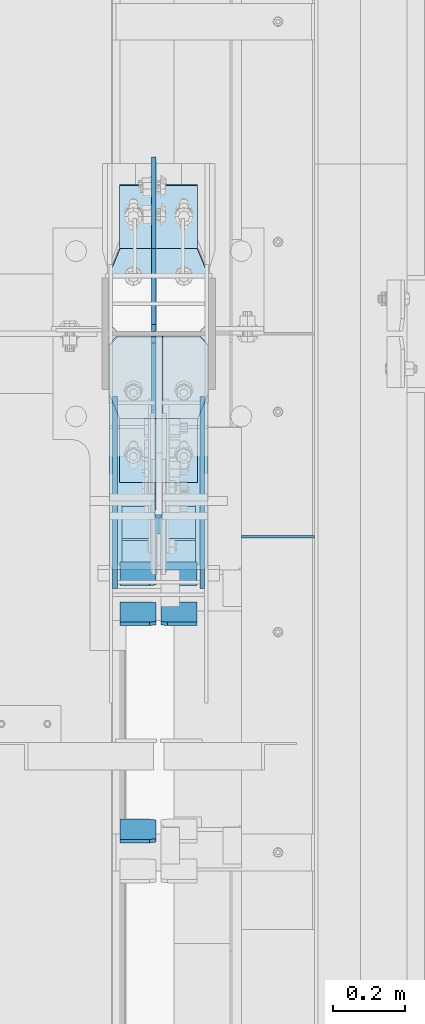
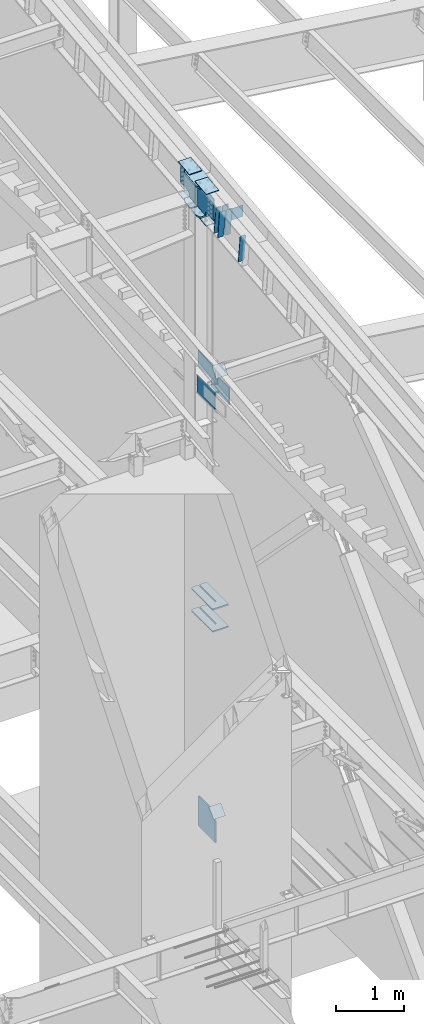
# One storey, part 1034 of 1179: 23 plates, 5 elements without a shape of their own.
"""IFC2X3 building model written with IfcOpenShell, lengths in millimetres."""

from ifc_helpers import new_model, si_unit, frame, origin_with_axes, place, context, subcontext, project, spatial, faceted_brep, material, type_object, element, aggregate, save


model = new_model("IFC2X3")

# Units and contexts
model_context = context("Model", 3, precision=1e-05, world=origin_with_axes())
body_context = subcontext(model_context, "Body", "Model", "MODEL_VIEW")
ifc_project = project(units=[si_unit("LENGTHUNIT", "METRE", prefix="MILLI"), si_unit("AREAUNIT", "SQUARE_METRE"), si_unit("VOLUMEUNIT", "CUBIC_METRE"), si_unit("MASSUNIT", "GRAM", prefix="KILO"), si_unit("TIMEUNIT", "SECOND"), si_unit("PLANEANGLEUNIT", "RADIAN"), si_unit("SOLIDANGLEUNIT", "STERADIAN"), si_unit("THERMODYNAMICTEMPERATUREUNIT", "DEGREE_CELSIUS"), si_unit("LUMINOUSINTENSITYUNIT", "LUMEN")], contexts=[model_context])

# Site, building, storey
site_placement = place(None, origin_with_axes())
site = spatial("IfcSite", under=ifc_project, at=site_placement, CompositionType="ELEMENT")
building_placement = place(site_placement, origin_with_axes())
building = spatial("IfcBuilding", under=site, at=building_placement, Name="Undefined", CompositionType="ELEMENT")
storey_placement = place(building_placement, origin_with_axes())
storey = spatial("IfcBuildingStorey", under=building, at=storey_placement, Name="Undefined", CompositionType="ELEMENT", Elevation=0.0)

# Assembly, plates
assembly_1_placement = place(storey_placement, origin_with_axes())
assembly_1 = element("IfcElementAssembly", 1, at=assembly_1_placement, inside=storey, Name="COLUMN", AssemblyPlace="NOTDEFINED", PredefinedType="RIGID_FRAME")
ifc_material_1 = material(Name="STEEL/A572-GR.50")
plate_type_1 = type_object("IfcPlateType", PredefinedType="NOTDEFINED")
plate_1_placement = place(assembly_1_placement, frame((24171.275012207, 18575.0015696771, 3694.1125), z_axis=(0.0, 1.0, 0.0), x_axis=(1.0, 0.0, 0.0)))
plate_1 = element("IfcPlate", 2, at=plate_1_placement, type_object=plate_type_1, material=ifc_material_1, Name="PLATE", context=body_context, shape_type="Brep", body=[
    faceted_brep([(125.412487792968, -11.1125000000002, 646.448430322878), (125.412487792968, -11.1125000000002, 153.987500190735), (125.412487792968, 11.1125000000002, 153.987500190735), (125.412487792968, 11.1125000000002, 646.448430322878), (126.258376502454, -11.1125000000002, 149.734930475586), (126.258376502454, 11.1125000000002, 149.734930475586), (128.667263742896, -11.1125000000002, 146.12977594993), (128.667263742896, 11.1125000000002, 146.12977594993), (132.272418268556, -11.1125000000002, 143.720888709488), (132.272418268556, 11.1125000000002, 143.720888709488), (136.524987602239, -11.1125000000002, 142.875), (136.524987602239, 11.1125000000002, 142.875), (140.777557317386, -11.1125000000002, 143.720888709488), (140.777557317386, 11.1125000000002, 143.720888709488), (144.382711843045, -11.1125000000002, 146.12977594993), (144.382711843045, 11.1125000000002, 146.12977594993), (146.791599083488, -11.1125000000002, 149.734930475586), (146.791599083488, 11.1125000000002, 149.734930475586), (147.637487792974, -11.1125000000002, 153.987500190735), (147.637487792974, 11.1125000000002, 153.987500190735), (147.637487792974, -11.1125000000002, 646.448430322878), (147.637487792974, 11.1125000000002, 646.448430322878), (0.0, -11.1125000000002, 624.223429941409), (22.2250003814697, -11.1125000000002, 646.448430322878), (22.2250003814697, 11.1125000000002, 646.448430322878), (0.0, 11.1125000000002, 624.223429941409), (0.0, -11.1125000000002, 15.875), (0.0, 11.1125000000002, 15.875), (6.34999990463257, -11.1125000000002, 0.0), (6.34999990463257, 11.1125000000002, 0.0), (266.699987888336, -11.1125000000002, 0.0), (266.699987888336, 11.1125000000002, 0.0), (273.049987792969, -11.1125000000002, 15.875), (273.049987792969, 11.1125000000002, 15.875), (273.049987792969, -11.1125000000002, 624.223429941409), (273.049987792969, 11.1125000000002, 624.223429941409), (250.824987411499, -11.1125000000002, 646.448430322878), (250.824987411499, 11.1125000000002, 646.448430322878)], [[[0, 1, 2, 3]], [[4, 5, 2, 1]], [[6, 7, 5, 4]], [[8, 9, 7, 6]], [[10, 11, 9, 8]], [[12, 13, 11, 10]], [[14, 15, 13, 12]], [[16, 17, 15, 14]], [[18, 19, 17, 16]], [[20, 21, 19, 18]], [[22, 23, 24, 25]], [[26, 22, 25, 27]], [[28, 26, 27, 29]], [[30, 28, 29, 31]], [[32, 30, 31, 33]], [[34, 32, 33, 35]], [[36, 34, 35, 37]], [[16, 14, 12, 10, 8, 6, 4, 1, 0, 23, 22, 26, 28, 30, 32, 34, 36, 20, 18]], [[24, 23, 0, 3]], [[37, 35, 33, 31, 29, 27, 25, 24, 3, 2, 5, 7, 9, 11, 13, 15, 17, 19, 21]], [[36, 37, 21, 20]]]),
])
plate_2_placement = place(assembly_1_placement, frame((24171.275012207, 18575.0015696771, 4090.9875), z_axis=(0.0, 1.0, 0.0), x_axis=(1.0, 0.0, 0.0)))
plate_2 = element("IfcPlate", 3, at=plate_2_placement, type_object=plate_type_1, material=ifc_material_1, Name="PLATE", context=body_context, shape_type="Brep", body=[
    faceted_brep([(125.412487792968, -11.1125000000002, 646.448430322878), (125.412487792968, -11.1125000000002, 153.987500190735), (125.412487792968, 11.1125000000002, 153.987500190735), (125.412487792968, 11.1125000000002, 646.448430322878), (126.258376502454, -11.1125000000002, 149.734930475586), (126.258376502454, 11.1125000000002, 149.734930475586), (128.667263742896, -11.1125000000002, 146.12977594993), (128.667263742896, 11.1125000000002, 146.12977594993), (132.272418268556, -11.1125000000002, 143.720888709488), (132.272418268556, 11.1125000000002, 143.720888709488), (136.524987602239, -11.1125000000002, 142.875), (136.524987602239, 11.1125000000002, 142.875), (140.777557317386, -11.1125000000002, 143.720888709488), (140.777557317386, 11.1125000000002, 143.720888709488), (144.382711843045, -11.1125000000002, 146.12977594993), (144.382711843045, 11.1125000000002, 146.12977594993), (146.791599083488, -11.1125000000002, 149.734930475586), (146.791599083488, 11.1125000000002, 149.734930475586), (147.637487792974, -11.1125000000002, 153.987500190735), (147.637487792974, 11.1125000000002, 153.987500190735), (147.637487792974, -11.1125000000002, 646.448430322878), (147.637487792974, 11.1125000000002, 646.448430322878), (0.0, -11.1125000000002, 624.223429941409), (22.2250003814697, -11.1125000000002, 646.448430322878), (22.2250003814697, 11.1125000000002, 646.448430322878), (0.0, 11.1125000000002, 624.223429941409), (0.0, -11.1125000000002, 15.875), (0.0, 11.1125000000002, 15.875), (6.34999990463257, -11.1125000000002, 0.0), (6.34999990463257, 11.1125000000002, 0.0), (266.699987888336, -11.1125000000002, 0.0), (266.699987888336, 11.1125000000002, 0.0), (273.049987792969, -11.1125000000002, 15.875), (273.049987792969, 11.1125000000002, 15.875), (273.049987792969, -11.1125000000002, 624.223429941409), (273.049987792969, 11.1125000000002, 624.223429941409), (250.824987411499, -11.1125000000002, 646.448430322878), (250.824987411499, 11.1125000000002, 646.448430322878)], [[[0, 1, 2, 3]], [[4, 5, 2, 1]], [[6, 7, 5, 4]], [[8, 9, 7, 6]], [[10, 11, 9, 8]], [[12, 13, 11, 10]], [[14, 15, 13, 12]], [[16, 17, 15, 14]], [[18, 19, 17, 16]], [[20, 21, 19, 18]], [[22, 23, 24, 25]], [[26, 22, 25, 27]], [[28, 26, 27, 29]], [[30, 28, 29, 31]], [[32, 30, 31, 33]], [[34, 32, 33, 35]], [[36, 34, 35, 37]], [[16, 14, 12, 10, 8, 6, 4, 1, 0, 23, 22, 26, 28, 30, 32, 34, 36, 20, 18]], [[24, 23, 0, 3]], [[37, 35, 33, 31, 29, 27, 25, 24, 3, 2, 5, 7, 9, 11, 13, 15, 17, 19, 21]], [[36, 37, 21, 20]]]),
])

# Assembly, plate
assembly_2_placement = place(storey_placement, origin_with_axes())
assembly_2 = element("IfcElementAssembly", 4, at=assembly_2_placement, inside=storey, Name="BEAM", AssemblyPlace="NOTDEFINED", PredefinedType="RIGID_FRAME")
ifc_material_2 = material(Name="STEEL/A36")
plate_type_2 = type_object("IfcPlateType", PredefinedType="NOTDEFINED")
plate_3_placement = place(assembly_2_placement, frame((24739.6, 18665.8250005413, 11099.2055869161), z_axis=(0.0, 0.0, -1.0), x_axis=(-1.0, 0.0, 0.0)))
plate_3 = element("IfcPlate", 5, at=plate_3_placement, type_object=plate_type_2, material=ifc_material_2, Name="CAP_PLATE", context=body_context, shape_type="Brep", body=[
    faceted_brep([(0.0, -3.17500000000109, 0.0), (0.0, -3.17499999999927, 204.492999998953), (0.0, 3.17499999999927, 204.492999998953), (0.0, 3.17500000000109, 7.27595761418343e-12), (203.199999999997, -3.17499999999927, 204.492999998953), (203.199999999997, 3.17499999999927, 204.492999998953), (203.199999999997, -3.17499999999927, 3.63797880709171e-12), (203.199999999997, 3.17499999999382, -3.63797880709171e-12)], [[[0, 1, 2, 3]], [[1, 4, 5, 2]], [[4, 6, 7, 5]], [[6, 0, 3, 7]], [[5, 7, 3, 2]], [[6, 4, 1, 0]]]),
])
aggregate(assembly_2, [plate_3])

assembly_3_placement = place(storey_placement, origin_with_axes())
assembly_3 = element("IfcElementAssembly", 6, at=assembly_3_placement, inside=storey, Name="Plate", AssemblyPlace="NOTDEFINED", PredefinedType="RIGID_FRAME")
plate_4_placement = place(assembly_3_placement, frame((24206.2, 18538.107881068, 8241.67671273193), z_axis=(0.0, 0.591857899923162, 0.806042322895358), x_axis=(1.0, 0.0, 0.0)))
plate_4 = element("IfcPlate", 7, at=plate_4_placement, type_object=plate_type_2, material=ifc_material_2, Name="Plate", context=body_context, shape_type="Brep", body=[
    faceted_brep([(0.0, -3.17500000000109, 0.0), (0.0, -3.17500000000291, 203.200000000368), (0.0, 3.17499999998836, 203.200000000361), (0.0, 3.17500000000109, 7.27595761418343e-12), (203.199999999997, -3.17500000000291, 203.200000000368), (203.199999999997, 3.17499999998836, 203.200000000361), (203.199999999997, -3.17499999999927, 3.63797880709171e-12), (203.199999999997, 3.17499999999382, -3.63797880709171e-12)], [[[0, 1, 2, 3]], [[1, 4, 5, 2]], [[4, 6, 7, 5]], [[6, 0, 3, 7]], [[5, 7, 3, 2]], [[6, 4, 1, 0]]]),
])
aggregate(assembly_3, [plate_4])

assembly_4_placement = place(storey_placement, origin_with_axes())
assembly_4 = element("IfcElementAssembly", 8, at=assembly_4_placement, inside=storey, Name="Plate", AssemblyPlace="NOTDEFINED", PredefinedType="RIGID_FRAME")
plate_5_placement = place(assembly_4_placement, frame((24206.2, 18604.2796707284, 297.334563911108), z_axis=(0.0, 0.727605443744036, 0.68599585875867), x_axis=(1.0, 0.0, 0.0)))
plate_5 = element("IfcPlate", 9, at=plate_5_placement, type_object=plate_type_2, material=ifc_material_2, Name="Plate", context=body_context, shape_type="Brep", body=[
    faceted_brep([(0.0, -3.17500000000109, 0.0), (0.0, -3.17500000000291, 203.200000000368), (0.0, 3.17499999998836, 203.200000000361), (0.0, 3.17500000000109, 7.27595761418343e-12), (203.199999999997, -3.17500000000291, 203.200000000368), (203.199999999997, 3.17499999998836, 203.200000000361), (203.199999999997, -3.17499999999927, 3.63797880709171e-12), (203.199999999997, 3.17499999999382, -3.63797880709171e-12)], [[[0, 1, 2, 3]], [[1, 4, 5, 2]], [[4, 6, 7, 5]], [[6, 0, 3, 7]], [[5, 7, 3, 2]], [[6, 4, 1, 0]]]),
])
aggregate(assembly_4, [plate_5])

# Plate
plate_type_3 = type_object("IfcPlateType", PredefinedType="NOTDEFINED")
plate_6_placement = place(assembly_1_placement, frame((24171.2749999998, 18991.1139130949, 11378.5871510539), z_axis=(1.0, 0.0, 0.0), x_axis=(0.0, 0.993683229349742, 0.112221387039499)))
plate_6 = element("IfcPlate", 10, at=plate_6_placement, type_object=plate_type_3, material=ifc_material_2, Name="PLATE", context=body_context, shape_type="Brep", body=[
    faceted_brep([(404.009737741189, -14.2874999996602, 8.31619217933621e-11), (71.43750000002, -14.287499999984, 2.90469870378729e-11), (71.4375000000155, 14.2874999999949, 2.90469870378729e-11), (404.009737741166, 14.2875000003405, 8.31619217933621e-11), (477.034739267168, 14.2875000004005, 30.162500381568), (473.810043726306, -14.287499999602, 28.8305609300143), (477.034739268025, 14.2875000004024, 242.887499623284), (473.810043726306, -14.287499999602, 244.219439075195), (404.009737742264, 14.2875000003405, 273.05000000474), (404.00973774229, -14.2874999996602, 273.05000000474), (71.4375000016116, -14.2874999999858, 273.049999999798), (71.4375000016071, 14.2874999999967, 273.049999999798), (4.20644072178584, 14.2875000000058, 244.663552394444), (0.979329666730337, -14.2874999999967, 243.30099437618), (0.979329666730337, -14.2874999999967, 29.7490056281208), (4.20644072178584, 14.2875000000058, 28.3864476098539)], [[[0, 1, 2, 3]], [[0, 3, 4, 5]], [[5, 4, 6, 7]], [[8, 9, 7, 6]], [[10, 9, 8, 11]], [[10, 11, 12, 13]], [[1, 0, 5, 7, 9, 10, 13, 14]], [[2, 1, 14, 15]], [[11, 8, 6, 4, 3, 2, 15, 12]], [[14, 13, 12, 15]]]),
])

plate_type_4 = type_object("IfcPlateType", PredefinedType="NOTDEFINED")
plate_7_placement = place(assembly_1_placement, frame((24428.45, 18523.1248035139, 8013.7), z_axis=(0.0, 0.0, -1.0), x_axis=(0.0, 1.0, 0.0)))
plate_7 = element("IfcPlate", 11, at=plate_7_placement, type_object=plate_type_4, material=ifc_material_1, Name="PLATE", context=body_context, shape_type="Brep", body=[
    faceted_brep([(0.0, -6.34999999999854, 0.0), (0.0, -6.34999999999854, 304.799999999999), (0.0, 6.34999999999854, 304.799999999999), (0.0, 6.34999999999854, 0.0), (531.637696486086, -6.34999999999854, 304.799999999999), (531.637696486086, 6.34999999999854, 304.799999999999), (531.637696486086, -6.34999999999854, 0.0), (531.637696486086, 6.34999999999854, 0.0)], [[[0, 1, 2, 3]], [[1, 4, 5, 2]], [[4, 6, 7, 5]], [[6, 0, 3, 7]], [[5, 7, 3, 2]], [[6, 4, 1, 0]]]),
])

plate_8_placement = place(assembly_1_placement, frame((24187.15, 18523.1248035139, 8013.7), z_axis=(0.0, 0.0, -1.0), x_axis=(0.0, 1.0, 0.0)))
plate_8 = element("IfcPlate", 12, at=plate_8_placement, type_object=plate_type_4, material=ifc_material_1, Name="PLATE", context=body_context, shape_type="Brep", body=[
    faceted_brep([(0.0, -6.34999999999854, 0.0), (0.0, -6.34999999999854, 304.799999999999), (0.0, 6.34999999999854, 304.799999999999), (0.0, 6.34999999999854, 0.0), (531.637696486086, -6.34999999999854, 304.799999999999), (531.637696486086, 6.34999999999854, 304.799999999999), (531.637696486086, -6.34999999999854, 0.0), (531.637696486086, 6.34999999999854, 0.0)], [[[0, 1, 2, 3]], [[1, 4, 5, 2]], [[4, 6, 7, 5]], [[6, 0, 3, 7]], [[5, 7, 3, 2]], [[6, 4, 1, 0]]]),
])

plate_type_5 = type_object("IfcPlateType", PredefinedType="NOTDEFINED")
plate_9_placement = place(assembly_1_placement, frame((24199.850003078, 19638.8732407573, 11472.5223933958), z_axis=(1.0, 0.0, 0.0), x_axis=(0.0, -0.993676146336441, -0.112284087038017)))
plate_9 = element("IfcPlate", 13, at=plate_9_placement, type_object=plate_type_5, material=ifc_material_1, Name="PLATE", context=body_context, shape_type="Brep", body=[
    faceted_brep([(0.0, -6.34999999999854, 0.0), (0.0, -6.350000000004, 215.899993896484), (0.0, 6.35000000000582, 215.899993896484), (0.0, 6.34999999999854, 0.0), (330.200000001782, -6.34999999994034, 215.899993896483), (330.200000001782, 6.35000000006767, 215.899993896483), (330.200000001782, -6.34999999994034, -1.47792889038101e-12), (330.200000001782, 6.35000000006767, -1.47792889038101e-12)], [[[0, 1, 2, 3]], [[1, 4, 5, 2]], [[4, 6, 7, 5]], [[6, 0, 3, 7]], [[5, 7, 3, 2]], [[6, 4, 1, 0]]]),
])

plate_10_placement = place(assembly_1_placement, frame((24199.8500030684, 18816.8882512744, 11379.6391794643), z_axis=(1.0, 0.0, 0.0), x_axis=(0.0, 0.993676146336441, 0.112284087038017)))
plate_10 = element("IfcPlate", 14, at=plate_10_placement, type_object=plate_type_5, material=ifc_material_1, Name="PLATE", context=body_context, shape_type="Brep", body=[
    faceted_brep([(0.0, -6.34999999999854, 0.0), (0.0, -6.350000000004, 215.899993896484), (0.0, 6.35000000000582, 215.899993896484), (0.0, 6.34999999999854, 0.0), (330.200000001782, -6.34999999994034, 215.899993896483), (330.200000001782, 6.35000000006767, 215.899993896483), (330.200000001782, -6.34999999994034, -1.47792889038101e-12), (330.200000001782, 6.35000000006767, -1.47792889038101e-12)], [[[0, 1, 2, 3]], [[1, 4, 5, 2]], [[4, 6, 7, 5]], [[6, 0, 3, 7]], [[5, 7, 3, 2]], [[6, 4, 1, 0]]]),
])

plate_11_placement = place(assembly_1_placement, frame((24199.8500030614, 19640.2992486406, 10907.0468457171), z_axis=(1.0, 0.0, 0.0), x_axis=(0.0, -0.993676146336441, -0.112284087038017)))
plate_11 = element("IfcPlate", 15, at=plate_11_placement, type_object=plate_type_5, material=ifc_material_1, Name="PLATE", context=body_context, shape_type="Brep", body=[
    faceted_brep([(0.0, -6.34999999999854, 0.0), (0.0, -6.350000000004, 215.899993896484), (0.0, 6.35000000000582, 215.899993896484), (0.0, 6.34999999999854, 0.0), (330.200000001782, -6.34999999994034, 215.899993896483), (330.200000001782, 6.35000000006767, 215.899993896483), (330.200000001782, -6.34999999994034, -1.47792889038101e-12), (330.200000001782, 6.35000000006767, -1.47792889038101e-12)], [[[0, 1, 2, 3]], [[1, 4, 5, 2]], [[4, 6, 7, 5]], [[6, 0, 3, 7]], [[5, 7, 3, 2]], [[6, 4, 1, 0]]]),
])

plate_12_placement = place(assembly_1_placement, frame((24199.8500030415, 18817.5392708214, 10814.0760589972), z_axis=(1.0, 0.0, 0.0), x_axis=(0.0, 0.993676146336441, 0.112284087038017)))
plate_12 = element("IfcPlate", 16, at=plate_12_placement, type_object=plate_type_5, material=ifc_material_1, Name="PLATE", context=body_context, shape_type="Brep", body=[
    faceted_brep([(0.0, -6.34999999999854, 0.0), (0.0, -6.350000000004, 215.899993896484), (0.0, 6.35000000000582, 215.899993896484), (0.0, 6.34999999999854, 0.0), (330.200000001782, -6.34999999994034, 215.899993896483), (330.200000001782, 6.35000000006767, 215.899993896483), (330.200000001782, -6.34999999994034, -1.47792889038101e-12), (330.200000001782, 6.35000000006767, -1.47792889038101e-12)], [[[0, 1, 2, 3]], [[1, 4, 5, 2]], [[4, 6, 7, 5]], [[6, 0, 3, 7]], [[5, 7, 3, 2]], [[6, 4, 1, 0]]]),
])

plate_type_6 = type_object("IfcPlateType", PredefinedType="NOTDEFINED")
plate_13_placement = place(assembly_1_placement, frame((24171.2749999997, 18991.1139131667, 10854.3676759149), z_axis=(1.0, 0.0, 0.0), x_axis=(0.0, 0.993676146336441, 0.112284087038017)))
plate_13 = element("IfcPlate", 17, at=plate_13_placement, type_object=plate_type_6, material=ifc_material_1, Name="PLATE", context=body_context, shape_type="Brep", body=[
    faceted_brep([(207.962499617965, -14.2875000000749, 8.87325768417213e-11), (71.43750000002, -14.287499999984, 2.90469870378729e-11), (71.4375000000155, 14.2874999999949, 2.90469870378729e-11), (207.962499617975, 14.2874999999094, 8.87325768417213e-11), (230.187499999511, -14.287500000084, 22.225000381568), (230.187499999523, 14.2874999999003, 22.225000381568), (230.187500000431, -14.2875000000822, 250.824999623284), (230.187500000442, 14.2874999998985, 250.824999623284), (207.962499619063, -14.2875000000731, 273.050000004745), (207.962499619074, 14.2874999999112, 273.050000004745), (71.4375000016116, -14.2874999999858, 273.049999999798), (71.4375000016071, 14.2874999999967, 273.049999999798), (4.20737223302058, 14.2874999999931, 244.663945699182), (0.978435120117865, -14.2874999999894, 243.300616678719), (0.978435120117865, -14.2874999999894, 29.7493833255772), (4.20737223302058, 14.2874999999931, 28.3860543051127)], [[[0, 1, 2, 3]], [[4, 0, 3, 5]], [[6, 4, 5, 7]], [[8, 6, 7, 9]], [[10, 8, 9, 11]], [[10, 11, 12, 13]], [[1, 0, 4, 6, 8, 10, 13, 14]], [[2, 1, 14, 15]], [[11, 9, 7, 5, 3, 2, 15, 12]], [[14, 13, 12, 15]]]),
])

# Assembly, plates
assembly_5_placement = place(storey_placement, origin_with_axes())
assembly_5 = element("IfcElementAssembly", 18, at=assembly_5_placement, inside=storey, Name="BEAM", AssemblyPlace="NOTDEFINED", PredefinedType="RIGID_FRAME")
plate_type_7 = type_object("IfcPlateType", PredefinedType="NOTDEFINED")
plate_14_placement = place(assembly_5_placement, frame((24300.65625, 17879.9307461562, 10740.079599516), z_axis=(0.0, -0.112284087038017, 0.993676146336441), x_axis=(-1.0, 0.0, 0.0)))
plate_14 = element("IfcPlate", 19, at=plate_14_placement, type_object=plate_type_7, material=ifc_material_2, Name="PLATE", context=body_context, shape_type="Brep", body=[
    faceted_brep([(-1.81898940354586e-12, -4.76249999999345, 17.4624996185303), (0.0, -4.76250000019354, 481.012500380073), (0.0, 4.76249999980064, 481.012500380079), (1.81898940354586e-12, 4.76250000000073, 17.4624996185303), (17.4624996185303, -4.76250000020082, 498.474999998594), (17.4624996185303, 4.76249999979336, 498.474999998596), (99.2187497618652, -4.76249999998072, 498.475), (99.2187499999927, 4.76250000001892, 498.475), (99.21875, -4.76250000000073, 0.0), (99.21875, 4.76249999999709, 3.63797880709171e-12), (17.4624996185157, -4.76250000000073, 0.0), (17.4624996185212, 4.76249999999345, 0.0)], [[[0, 1, 2, 3]], [[1, 4, 5, 2]], [[4, 6, 7, 5]], [[6, 8, 9, 7]], [[8, 10, 11, 9]], [[10, 0, 3, 11]], [[5, 7, 9, 11, 3, 2]], [[10, 8, 6, 4, 1, 0]]]),
])
plate_15_placement = place(assembly_5_placement, frame((24414.1625, 18481.1456193623, 10808.0160830477), z_axis=(0.0, -0.112284087038017, 0.993676146336441), x_axis=(-1.0, 0.0, 0.0)))
plate_15 = element("IfcPlate", 20, at=plate_15_placement, type_object=plate_type_7, material=ifc_material_2, Name="PLATE", context=body_context, shape_type="Brep", body=[
    faceted_brep([(0.0, -4.76249999999709, 0.0), (0.0, -4.76250000020082, 498.474999998594), (0.0, 4.76249999979336, 498.474999998596), (0.0, 4.76249999999709, 0.0), (81.7562503814697, -4.76250000020082, 498.474999998594), (81.7562503814697, 4.76249999979336, 498.474999998596), (99.21875, -4.76250000019354, 481.012500380073), (99.21875, 4.76249999980064, 481.012500380079), (99.21875, -4.76250000000437, 17.4624996185212), (99.21875, 4.76249999998981, 17.4624996185248), (81.7562503814697, -4.76250000000073, 0.0), (81.7562503814697, 4.76249999999709, 3.63797880709171e-12)], [[[0, 1, 2, 3]], [[1, 4, 5, 2]], [[4, 6, 7, 5]], [[6, 8, 9, 7]], [[8, 10, 11, 9]], [[10, 0, 3, 11]], [[5, 7, 9, 11, 3, 2]], [[10, 8, 6, 4, 1, 0]]]),
])
plate_16_placement = place(assembly_5_placement, frame((24300.65625, 18481.1456193623, 10808.0160830477), z_axis=(0.0, -0.112284087038017, 0.993676146336441), x_axis=(-1.0, 0.0, 0.0)))
plate_16 = element("IfcPlate", 21, at=plate_16_placement, type_object=plate_type_7, material=ifc_material_2, Name="PLATE", context=body_context, shape_type="Brep", body=[
    faceted_brep([(-1.81898940354586e-12, -4.76249999999345, 17.4624996185303), (0.0, -4.76250000019354, 481.012500380073), (0.0, 4.76249999980064, 481.012500380079), (1.81898940354586e-12, 4.76250000000073, 17.4624996185303), (17.4624996185303, -4.76250000020082, 498.474999998594), (17.4624996185303, 4.76249999979336, 498.474999998596), (99.2187497618652, -4.76249999998072, 498.475), (99.2187499999927, 4.76250000001892, 498.475), (99.21875, -4.76250000000073, 0.0), (99.21875, 4.76249999999709, 3.63797880709171e-12), (17.4624996185157, -4.76250000000073, 0.0), (17.4624996185212, 4.76249999999345, 0.0)], [[[0, 1, 2, 3]], [[1, 4, 5, 2]], [[4, 6, 7, 5]], [[6, 8, 9, 7]], [[8, 10, 11, 9]], [[10, 0, 3, 11]], [[5, 7, 9, 11, 3, 2]], [[10, 8, 6, 4, 1, 0]]]),
])
plate_17_placement = place(assembly_5_placement, frame((24414.1625, 18591.5678811239, 10820.4936522197), z_axis=(0.0, -0.112284087038017, 0.993676146336441), x_axis=(-1.0, 0.0, 0.0)))
plate_17 = element("IfcPlate", 22, at=plate_17_placement, type_object=plate_type_7, material=ifc_material_2, Name="PLATE", context=body_context, shape_type="Brep", body=[
    faceted_brep([(0.0, -4.76249999999709, 0.0), (0.0, -4.76250000020082, 498.474999998594), (0.0, 4.76249999979336, 498.474999998596), (0.0, 4.76249999999709, 0.0), (81.7562503814697, -4.76250000020082, 498.474999998594), (81.7562503814697, 4.76249999979336, 498.474999998596), (99.21875, -4.76250000019354, 481.012500380073), (99.21875, 4.76249999980064, 481.012500380079), (99.21875, -4.76250000000437, 17.4624996185212), (99.21875, 4.76249999998981, 17.4624996185248), (81.7562503814697, -4.76250000000073, 0.0), (81.7562503814697, 4.76249999999709, 3.63797880709171e-12)], [[[0, 1, 2, 3]], [[1, 4, 5, 2]], [[4, 6, 7, 5]], [[6, 8, 9, 7]], [[8, 10, 11, 9]], [[10, 0, 3, 11]], [[5, 7, 9, 11, 3, 2]], [[10, 8, 6, 4, 1, 0]]]),
])
plate_18_placement = place(assembly_5_placement, frame((24300.65625, 18591.5678811239, 10820.4936522197), z_axis=(0.0, -0.112284087038017, 0.993676146336441), x_axis=(-1.0, 0.0, 0.0)))
plate_18 = element("IfcPlate", 23, at=plate_18_placement, type_object=plate_type_7, material=ifc_material_2, Name="PLATE", context=body_context, shape_type="Brep", body=[
    faceted_brep([(-1.81898940354586e-12, -4.76249999999345, 17.4624996185303), (0.0, -4.76250000019354, 481.012500380073), (0.0, 4.76249999980064, 481.012500380079), (1.81898940354586e-12, 4.76250000000073, 17.4624996185303), (17.4624996185303, -4.76250000020082, 498.474999998594), (17.4624996185303, 4.76249999979336, 498.474999998596), (99.2187497618652, -4.76249999998072, 498.475), (99.2187499999927, 4.76250000001892, 498.475), (99.21875, -4.76250000000073, 0.0), (99.21875, 4.76249999999709, 3.63797880709171e-12), (17.4624996185157, -4.76250000000073, 0.0), (17.4624996185212, 4.76249999999345, 0.0)], [[[0, 1, 2, 3]], [[1, 4, 5, 2]], [[4, 6, 7, 5]], [[6, 8, 9, 7]], [[8, 10, 11, 9]], [[10, 0, 3, 11]], [[5, 7, 9, 11, 3, 2]], [[10, 8, 6, 4, 1, 0]]]),
])
aggregate(assembly_5, [plate_14, plate_15, plate_16, plate_17, plate_18])

# Plate
plate_type_8 = type_object("IfcPlateType", PredefinedType="NOTDEFINED")
plate_19_placement = place(assembly_1_placement, frame((24444.325, 19466.0635477103, 10908.0363549589), z_axis=(-1.0, 0.0, 0.0), x_axis=(0.0, -0.993676146336441, -0.112284087038017)))
plate_19 = element("IfcPlate", 24, at=plate_19_placement, type_object=plate_type_8, material=ifc_material_1, Name="PLATE", context=body_context, shape_type="Brep", body=[
    faceted_brep([(209.549999618157, -14.287499999904, 0.0), (73.0250015258425, -14.2874999999603, 0.0), (73.0250015258298, 14.2875000000258, 0.0), (209.549999618144, 14.2875000000804, 0.0), (231.774999999612, -14.2874999998949, 22.2250003814697), (231.774999999603, 14.2875000000895, 22.2250003814697), (231.774999999612, -14.2874999998949, 250.824999618533), (231.774999999603, 14.2875000000895, 250.824999618533), (209.549999618157, -14.287499999904, 273.050000000002), (209.549999618144, 14.2875000000804, 273.050000000002), (73.0250015258425, -14.2874999999603, 273.049999999998), (73.0250015258298, 14.2875000000258, 273.049999999998), (4.15974163581814, -14.2874999999876, 244.605653758279), (4.15974163581814, -14.2874999999876, 28.4443462417166), (0.930804522917242, 14.2874999999949, 29.7780376469105), (0.930804522917242, 14.2874999999949, 243.271962353085)], [[[0, 1, 2, 3]], [[4, 0, 3, 5]], [[6, 4, 5, 7]], [[8, 6, 7, 9]], [[10, 8, 9, 11]], [[1, 0, 4, 6, 8, 10, 12, 13]], [[2, 1, 13, 14]], [[11, 9, 7, 5, 3, 2, 14, 15]], [[10, 11, 15, 12]], [[14, 13, 12, 15]]]),
])

plate_type_9 = type_object("IfcPlateType", PredefinedType="NOTDEFINED")
plate_20_placement = place(assembly_1_placement, frame((24294.30625, 19234.1499999827, 10915.2285667486), z_axis=(0.0, 0.663574933899741, 0.748109822886957), x_axis=(0.0, 0.748109822886957, -0.663574933899741)))
plate_20 = element("IfcPlate", 25, at=plate_20_placement, type_object=plate_type_9, material=ifc_material_1, Name="PLATE", context=body_context, shape_type="Brep", body=[
    faceted_brep([(-303.402323060972, -6.34999999999854, 370.580774758848), (-303.402323060805, 6.34999999999854, 370.580774758702), (-303.504098483867, 6.35000000000002, 342.168708916848), (-303.504098483867, -6.35000000000002, 342.168708916848), (25.4641550948563, -6.35000000000002, 0.0), (0.0, -6.34999999999854, 0.0), (0.0, 6.34999999999854, 0.0), (25.4641550948563, 6.35000000000002, 0.0), (167.045917247172, -6.35000000000002, 157.353263970723), (167.045917247172, 6.35000000000002, 157.353263970723), (131.563526715495, -6.35000000000002, 197.355899250204), (131.563526715495, 6.35000000000002, 197.355899250204), (126.802866418006, -6.35000000000002, 205.238730036501), (126.802866418006, 6.35000000000002, 205.238730036501), (125.165683086001, -6.35000000000002, 214.300878700633), (125.165683086001, 6.35000000000002, 214.300878700633), (126.867175912115, -6.35000000000002, 223.351173161929), (126.867175912115, 6.35000000000002, 223.351173161929), (131.683692556814, -6.35000000000002, 231.199999512715), (131.683692556814, 6.35000000000002, 231.199999512715), (286.794657668127, -6.35000000000002, 403.589566389341), (286.794657668127, 6.35000000000002, 403.589566389341), (23.8827060644498, -6.35000000000002, 699.99493122035), (23.8827060644498, 6.35000000000002, 699.99493122035), (-127.388721232707, -6.35000000000002, 531.872607863961), (-127.388721232707, 6.35000000000002, 531.872607863961), (-134.060951024564, -6.35000000000002, 526.588932486246), (-134.060951024564, 6.35000000000002, 526.588932486246), (-142.104023886786, -6.35000000000002, 523.805974558898), (-142.104023886786, 6.35000000000002, 523.805974558898), (-150.614897093323, -6.35000000000002, 523.836193008534), (-150.614897093323, 6.35000000000002, 523.836193008534), (-158.638005243585, -6.35000000000002, 526.676195033468), (-158.638005243585, 6.35000000000002, 526.676195033468), (-161.131532852267, 6.35000000000002, 528.679769861075), (-161.131532852267, -6.35000000000002, 528.679769861075)], [[[0, 1, 2, 3]], [[4, 5, 6, 7]], [[8, 4, 7, 9]], [[10, 8, 9, 11]], [[12, 10, 11, 13]], [[14, 12, 13, 15]], [[16, 14, 15, 17]], [[18, 16, 17, 19]], [[20, 18, 19, 21]], [[22, 20, 21, 23]], [[24, 22, 23, 25]], [[26, 24, 25, 27]], [[28, 26, 27, 29]], [[30, 28, 29, 31]], [[32, 30, 31, 33]], [[32, 33, 34, 35]], [[5, 4, 8, 10, 12, 14, 16, 18, 20, 22, 24, 26, 28, 30, 32, 35, 0, 3]], [[6, 5, 3, 2]], [[34, 33, 31, 29, 27, 25, 23, 21, 19, 17, 15, 13, 11, 9, 7, 6, 2, 1]], [[35, 34, 1, 0]]]),
])

plate_type_10 = type_object("IfcPlateType", PredefinedType="NOTDEFINED")
plate_21_placement = place(assembly_1_placement, frame((24294.30625, 19221.45, 10913.428379323), z_axis=(0.0, -0.743858433013958, 0.668337214012522), x_axis=(0.0, -0.668337214012522, -0.743858433013957)))
plate_21 = element("IfcPlate", 26, at=plate_21_placement, type_object=plate_type_10, material=ifc_material_1, Name="PLATE", context=body_context, shape_type="Brep", body=[
    faceted_brep([(-340.425158086084, -6.34999999999854, 331.31098111851), (-340.425158086702, 6.34999999999854, 331.310981119209), (-340.496288379261, 6.35000000000002, 305.926948789638), (-340.496288379261, -6.35000000000002, 305.926948789638), (28.5035613092805, -6.35000000000002, -1.04591890703887e-11), (0.0, -6.34999999999854, 0.0), (0.0, 6.34999999999854, 0.0), (28.5035613092805, 6.35000000000002, -1.04591890703887e-11), (185.535041792471, -6.35000000000002, 139.488379402524), (185.535041792471, 6.35000000000002, 139.488379402524), (150.391206739107, -6.35000000000002, 171.064189752232), (150.391206739107, 6.35000000000002, 171.064189752232), (145.102749755571, -6.35000000000002, 177.732630246504), (145.102749755571, 6.35000000000002, 177.732630246504), (142.314026896069, -6.35000000000002, 185.773706089029), (142.314026896069, 6.35000000000002, 185.773706089029), (142.338144349787, -6.35000000000002, 194.28459877081), (142.338144349787, 6.35000000000002, 194.28459877081), (145.172394309466, -6.35000000000002, 202.30974070466), (145.172394309466, 6.35000000000002, 202.30974070466), (150.498558992693, -6.35000000000002, 208.948102374491), (150.498558992693, 6.35000000000002, 208.948102374491), (319.572465694362, -6.35000000000002, 359.133576332748), (319.572465694362, 6.35000000000002, 359.133576332748), (24.8516291671876, -6.35000000000002, 623.932487042394), (24.8516291671876, 6.35000000000002, 623.932487042394), (-148.513946545472, -6.35000000000002, 469.934796538949), (-148.513946545472, 6.35000000000002, 469.934796538949), (-156.393362644572, -6.35000000000002, 465.168486686387), (-156.393362644572, 6.35000000000002, 465.168486686387), (-165.454335371476, -6.35000000000002, 463.524807607098), (-165.454335371476, 6.35000000000002, 463.524807607098), (-174.505847216309, -6.35000000000002, 465.219812325748), (-174.505847216309, 6.35000000000002, 465.219812325748), (-182.358124252696, -6.35000000000002, 470.030701330617), (-182.358124252696, 6.35000000000002, 470.030701330617), (-183.313079553001, 6.35000000000002, 470.888703537204), (-183.313079553001, -6.35000000000002, 470.888703537204)], [[[0, 1, 2, 3]], [[4, 5, 6, 7]], [[8, 4, 7, 9]], [[10, 8, 9, 11]], [[12, 10, 11, 13]], [[14, 12, 13, 15]], [[16, 14, 15, 17]], [[18, 16, 17, 19]], [[20, 18, 19, 21]], [[22, 20, 21, 23]], [[24, 22, 23, 25]], [[26, 24, 25, 27]], [[28, 26, 27, 29]], [[30, 28, 29, 31]], [[32, 30, 31, 33]], [[34, 32, 33, 35]], [[34, 35, 36, 37]], [[5, 4, 8, 10, 12, 14, 16, 18, 20, 22, 24, 26, 28, 30, 32, 34, 37, 0, 3]], [[6, 5, 3, 2]], [[36, 35, 33, 31, 29, 27, 25, 23, 21, 19, 17, 15, 13, 11, 9, 7, 6, 2, 1]], [[37, 36, 1, 0]]]),
])

plate_type_11 = type_object("IfcPlateType", PredefinedType="NOTDEFINED")
plate_22_placement = place(assembly_1_placement, frame((24307.8, 19221.45, 8026.4), z_axis=(0.0, 0.0, 1.0), x_axis=(0.0, -1.0, 0.0)))
plate_22 = element("IfcPlate", 27, at=plate_22_placement, type_object=plate_type_11, material=ifc_material_1, Name="PLATE", context=body_context, shape_type="Brep", body=[
    faceted_brep([(0.0, -9.52500000000146, 19.0499992370605), (0.0, -9.52500000000146, 283.469358990927), (0.0, 9.52500000000146, 283.469358990927), (0.0, 9.52500000000146, 19.0499992370605), (408.746914534087, -9.52500000000146, 283.469358990927), (408.746914534087, 9.52500000000146, 283.469358990927), (545.92477928878, -9.52500000000146, 96.6488996018561), (545.92477928878, 9.52500000000146, 96.6488996018561), (545.92477928878, -9.52500000000146, 0.0), (545.92477928878, 9.52500000000146, 0.0), (19.0499992370605, -9.52500000000146, 0.0), (19.0499992370605, 9.52500000000146, 0.0)], [[[0, 1, 2, 3]], [[1, 4, 5, 2]], [[4, 6, 7, 5]], [[6, 8, 9, 7]], [[8, 10, 11, 9]], [[10, 0, 3, 11]], [[5, 7, 9, 11, 3, 2]], [[10, 8, 6, 4, 1, 0]]]),
])

plate_type_12 = type_object("IfcPlateType", PredefinedType="NOTDEFINED")
plate_23_placement = place(assembly_1_placement, frame((24307.8, 19221.45, -215.899999999999), z_axis=(0.0, 0.0, 1.0), x_axis=(0.0, -1.0, 0.0)))
plate_23 = element("IfcPlate", 28, at=plate_23_placement, type_object=plate_type_12, material=ifc_material_1, Name="PLATE", context=body_context, shape_type="Brep", body=[
    faceted_brep([(0.0, -12.7000000000007, 19.0500000000029), (0.0, -12.7, 534.018748335632), (0.0, 12.7, 534.018748335632), (0.0, 12.7000000000007, 19.0500000000029), (331.311918860847, -12.7, 534.018748335632), (331.311918860847, 12.7, 534.018748335632), (506.88311243628, -12.7, 368.487947617164), (506.88311243628, 12.7, 368.487947617164), (506.88311243628, -12.7, 0.0), (506.88311243628, 12.7, 0.0), (19.0499992370605, -12.6999999999971, 0.0), (19.0499992370605, 12.6999999999971, 0.0)], [[[0, 1, 2, 3]], [[1, 4, 5, 2]], [[4, 6, 7, 5]], [[6, 8, 9, 7]], [[8, 10, 11, 9]], [[10, 0, 3, 11]], [[5, 7, 9, 11, 3, 2]], [[10, 8, 6, 4, 1, 0]]]),
])

aggregate(assembly_1, [plate_7, plate_8, plate_1, plate_2, plate_9, plate_10, plate_6, plate_11, plate_12, plate_19, plate_20, plate_13, plate_21, plate_23, plate_22])

save(model, "model.ifc")
